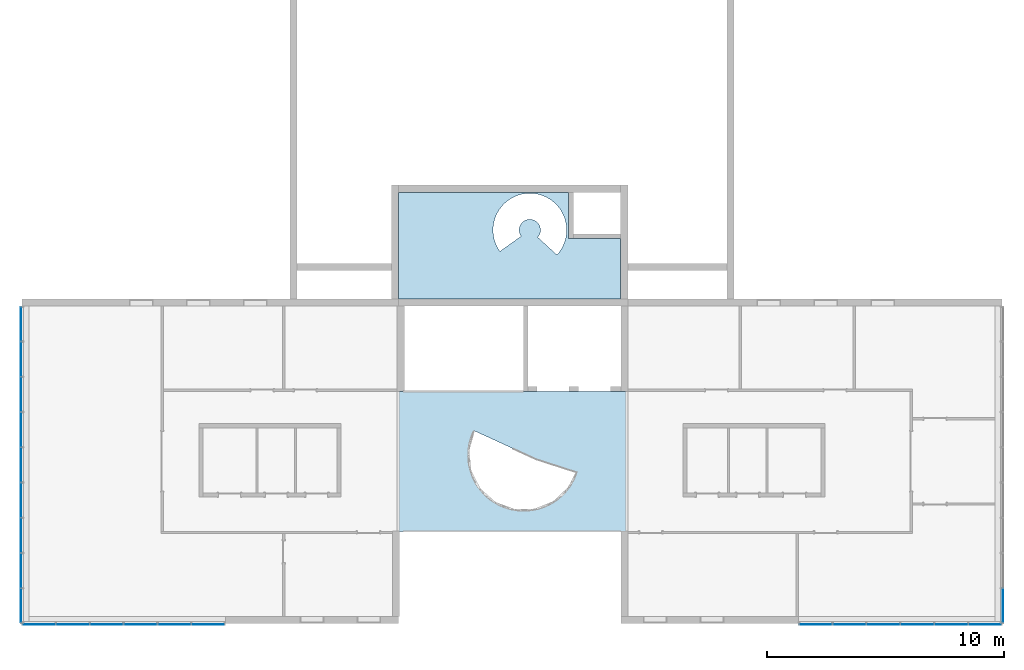
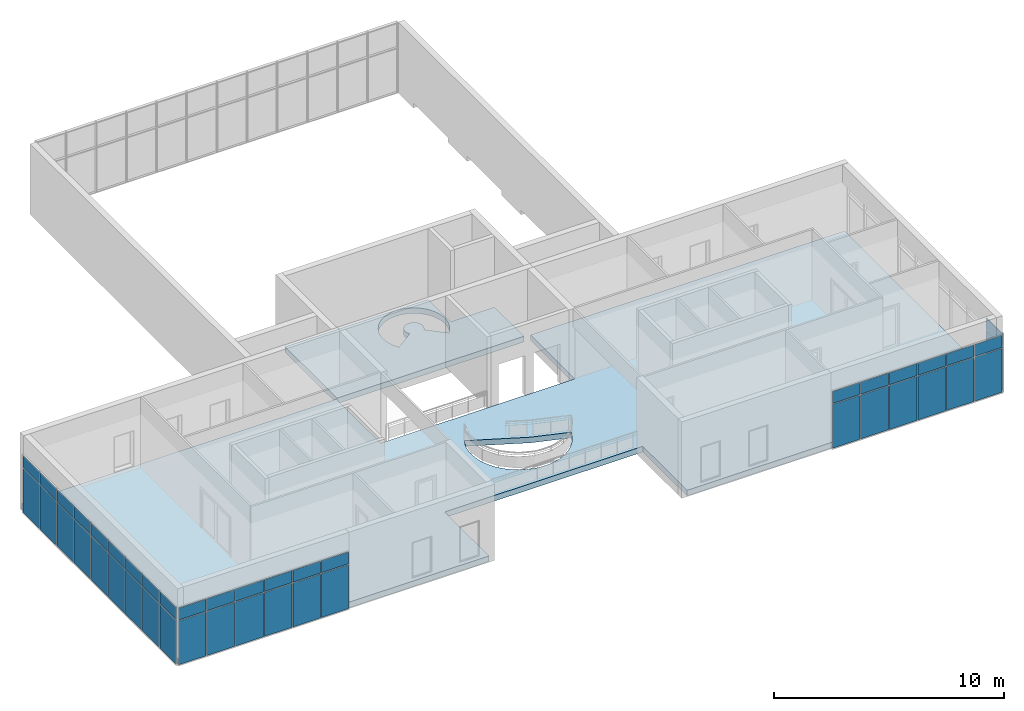
# One storey, part 8 of 13: 44 plates, 2 slabs, 2 openings, 4 elements without a shape of their own.
"""IFC2X3 building model written with IfcOpenShell, lengths in millimetres."""

import ifcopenshell
import ifcopenshell.guid

model = None  # the IFC model being written
_history = None  # IfcOwnerHistory: only IFC2X3 demands one
_inside = {}  # id of a spatial element -> (the spatial element, [elements in it])
_under = {}  # id of a project, library or spatial element -> (it, [spatial elements below it])
_declared = {}  # id of a project -> (the project, [libraries it declares])
_typed = {}  # id of a type object -> (the type object, [elements of that type])
_made_of = {}  # id of a material, layer set ... -> (it, [elements and type objects made of it])


def new_model(schema):
    """Start an empty IFC model of exactly this schema.

    Asked for "IFC4X3", IfcOpenShell would pick the latest addendum, in which some entities
    have other attributes; the version numbers below select the first issue.
    IFC2X3 requires an IfcOwnerHistory on every rooted entity: one is made here for all.
    """
    global model, _history
    if schema == "IFC4X3":
        model = ifcopenshell.file(schema_version=(4, 3, 0, 0))
    else:
        model = ifcopenshell.file(schema=schema)
    _inside.clear()
    _under.clear()
    _declared.clear()
    _typed.clear()
    _made_of.clear()
    _history = None
    if model.schema == "IFC2X3":
        org = make("IfcOrganization", Name="unknown")
        user = make(
            "IfcPersonAndOrganization",
            ThePerson=make("IfcPerson", FamilyName="unknown"),
            TheOrganization=org,
        )
        app = make(
            "IfcApplication",
            ApplicationDeveloper=org,
            Version="unknown",
            ApplicationFullName="unknown",
            ApplicationIdentifier="unknown",
        )
        _history = make(
            "IfcOwnerHistory",
            OwningUser=user,
            OwningApplication=app,
            ChangeAction="ADDED",
            CreationDate=0,
        )
    return model


def make(cls, **values):
    """One entity of the class cls with the attributes given. An attribute that is None is left unset."""
    return model.create_entity(
        cls, **{name: value for name, value in values.items() if value is not None}
    )


def entity(cls, *values):
    """Any entity or typed value of the class cls, its attributes in the order of the schema. None: left unset."""
    e = model.create_entity(cls)
    for i, value in enumerate(values):
        if value is not None:
            e[i] = value
    return e


def rooted(cls, **values):
    """An entity with a GlobalId (a new one), such as an element, a storey or a relation."""
    return make(cls, GlobalId=ifcopenshell.guid.new(), OwnerHistory=_history, **values)


def si_unit(unit_type, name, prefix=None):
    """IfcSIUnit, for example si_unit("LENGTHUNIT", "METRE", prefix="MILLI")."""
    return make("IfcSIUnit", UnitType=unit_type, Prefix=prefix, Name=name)


def converted_unit(unit_type, name, factor, base, dimensions=None, offset=None):
    """IfcConversionBasedUnit, such as the inch: factor (a typed value) times the base unit."""
    return make(
        "IfcConversionBasedUnit"
        if offset is None
        else "IfcConversionBasedUnitWithOffset",
        ConversionOffset=offset,
        Dimensions=None
        if dimensions is None
        else entity("IfcDimensionalExponents", *dimensions),
        UnitType=unit_type,
        Name=name,
        ConversionFactor=make(
            "IfcMeasureWithUnit", ValueComponent=factor, UnitComponent=base
        ),
    )


def derived_unit(unit_type, elements):
    """IfcDerivedUnit: a product of units, each with its exponent."""
    return make(
        "IfcDerivedUnit",
        Elements=[
            make("IfcDerivedUnitElement", Unit=unit, Exponent=power)
            for unit, power in elements
        ],
        UnitType=unit_type,
    )


def assignment(units):
    """IfcUnitAssignment: the units of a project."""
    return None if units is None else make("IfcUnitAssignment", Units=units)


def point(xyz):
    """IfcCartesianPoint."""
    return None if xyz is None else make("IfcCartesianPoint", Coordinates=xyz)


def direction(xyz):
    """IfcDirection."""
    return None if xyz is None else make("IfcDirection", DirectionRatios=xyz)


def frame(location, z_axis=None, x_axis=None):
    """IfcAxis2Placement3D, a coordinate frame: its origin and axes. An axis left out is left unset."""
    return make(
        "IfcAxis2Placement3D",
        Location=point(location),
        Axis=direction(z_axis),
        RefDirection=direction(x_axis),
    )


def frame_2d(location, x_axis=None):
    """IfcAxis2Placement2D, a coordinate frame in the plane: its origin and x axis."""
    return make(
        "IfcAxis2Placement2D", Location=point(location), RefDirection=direction(x_axis)
    )


def origin():
    """The frame at (0, 0, 0) with its axes left unset."""
    return frame((0.0, 0.0, 0.0))


def origin_2d_with_axis():
    """The frame at (0, 0) in the plane with the x axis (1, 0) written out."""
    return frame_2d((0.0, 0.0), x_axis=(1.0, 0.0))


def place(relative_to, where):
    """IfcLocalPlacement: puts the frame where relative to a parent placement (None: the world)."""
    return make(
        "IfcLocalPlacement", PlacementRelTo=relative_to, RelativePlacement=where
    )


def context(
    kind, dimensions, precision=None, world=None, true_north=None, identifier=None
):
    """IfcGeometricRepresentationContext, for example the 3D "Model" context."""
    return make(
        "IfcGeometricRepresentationContext",
        ContextIdentifier=identifier,
        ContextType=kind,
        CoordinateSpaceDimension=dimensions,
        Precision=precision,
        WorldCoordinateSystem=world,
        TrueNorth=true_north,
    )


def subcontext(parent, identifier, kind, view, scale=None):
    """IfcGeometricRepresentationSubContext, for example "Body" below "Model"."""
    return make(
        "IfcGeometricRepresentationSubContext",
        ContextIdentifier=identifier,
        ContextType=kind,
        ParentContext=parent,
        TargetScale=scale,
        TargetView=view,
    )


def project(units=None, contexts=None):
    """IfcProject with its units and contexts."""
    return rooted(
        "IfcProject",
        Name="project",
        RepresentationContexts=contexts,
        UnitsInContext=assignment(units),
    )


def spatial(cls, under=None, at=None, **own):
    """A site, building, storey or space (cls), placed at a placement, below another one or the project."""
    s = rooted(cls, ObjectPlacement=at, **own)
    if under is not None:
        _under.setdefault(under.id(), (under, []))[1].append(s)
    return s


def polyline(points):
    """IfcPolyline through the points."""
    return make("IfcPolyline", Points=[point(p) for p in points])


def circle_curve(where, radius):
    """IfcCircle in the frame where."""
    return make("IfcCircle", Position=where, Radius=radius)


def parameter(value):
    """IfcParameterValue: where a trimmed curve begins or ends, as a parameter of its basis curve."""
    return model.create_entity("IfcParameterValue", value)


def trimmed(basis, trim1, trim2, sense, master):
    """IfcTrimmedCurve: the piece of a basis curve between two trims."""
    return make(
        "IfcTrimmedCurve",
        BasisCurve=basis,
        Trim1=trim1,
        Trim2=trim2,
        SenseAgreement=sense,
        MasterRepresentation=master,
    )


def segment(curve, same_sense, transition):
    """IfcCompositeCurveSegment."""
    return make(
        "IfcCompositeCurveSegment",
        Transition=transition,
        SameSense=same_sense,
        ParentCurve=curve,
    )


def composite_curve(segments, self_intersect=None):
    """IfcCompositeCurve: segments joined end to end."""
    return make("IfcCompositeCurve", Segments=segments, SelfIntersect=self_intersect)


def profile(cls, at=None, kind="AREA", **sizes):
    """A parametric profile (cls). Its sizes go by their IFC names, for example OverallWidth=200.0."""
    return make(cls, ProfileType=kind, Position=at, **sizes)


def rectangle(**sizes):
    """IfcRectangleProfileDef."""
    return profile("IfcRectangleProfileDef", **sizes)


def outline(outer, holes=None, kind="AREA"):
    """IfcArbitraryClosedProfileDef: a profile drawn as a closed curve; with holes, ...WithVoids."""
    if holes is None:
        return make("IfcArbitraryClosedProfileDef", ProfileType=kind, OuterCurve=outer)
    return make(
        "IfcArbitraryProfileDefWithVoids",
        ProfileType=kind,
        OuterCurve=outer,
        InnerCurves=holes,
    )


def extrude(swept, where, along, depth):
    """IfcExtrudedAreaSolid: the profile swept, set in the frame where, extruded along a direction by depth."""
    return make(
        "IfcExtrudedAreaSolid",
        SweptArea=swept,
        Position=where,
        ExtrudedDirection=direction(along),
        Depth=depth,
    )


def shape(context_of_items, identifier, shape_type, items):
    """IfcShapeRepresentation: the items that make up one representation, for example the "Body"."""
    return make(
        "IfcShapeRepresentation",
        ContextOfItems=context_of_items,
        RepresentationIdentifier=identifier,
        RepresentationType=shape_type,
        Items=items,
    )


def source(mapping_origin, context_of_items, identifier, shape_type, items):
    """IfcRepresentationMap: a shape defined once, which mapped items show again and again."""
    return make(
        "IfcRepresentationMap",
        MappingOrigin=mapping_origin,
        MappedRepresentation=shape(context_of_items, identifier, shape_type, items),
    )


def transform(
    local_origin,
    x_axis=None,
    y_axis=None,
    z_axis=None,
    scale=None,
    scale2=None,
    scale3=None,
    uniform=True,
):
    """IfcCartesianTransformationOperator3D, or its non-uniform kind. x_axis, y_axis, z_axis: its Axis1, 2, 3."""
    if uniform:
        return make(
            "IfcCartesianTransformationOperator3D",
            Axis1=direction(x_axis),
            Axis2=direction(y_axis),
            LocalOrigin=point(local_origin),
            Scale=scale,
            Axis3=direction(z_axis),
        )
    return make(
        "IfcCartesianTransformationOperator3DnonUniform",
        Axis1=direction(x_axis),
        Axis2=direction(y_axis),
        LocalOrigin=point(local_origin),
        Scale=scale,
        Axis3=direction(z_axis),
        Scale2=scale2,
        Scale3=scale3,
    )


def mapped(mapping_source, mapping_target):
    """IfcMappedItem: shows the shape of a source again, moved by a transform."""
    return make(
        "IfcMappedItem", MappingSource=mapping_source, MappingTarget=mapping_target
    )


def material(Name=None, Category=None):
    """IfcMaterial."""
    return make("IfcMaterial", Name=Name, Category=Category)


def layer(
    of_material, thickness, ventilated=None, Name=None, Category=None, Priority=None
):
    """IfcMaterialLayer: one layer of a wall or slab, of a material (None: an air gap)."""
    return make(
        "IfcMaterialLayer",
        Material=of_material,
        LayerThickness=thickness,
        IsVentilated=ventilated,
        Name=Name,
        Category=Category,
        Priority=Priority,
    )


def layer_set(layers, Name=None):
    """IfcMaterialLayerSet."""
    return make("IfcMaterialLayerSet", MaterialLayers=layers, LayerSetName=Name)


def layer_usage(for_layer_set, set_direction, sense, offset, extent=None):
    """IfcMaterialLayerSetUsage: how a layer set lies in its element."""
    return make(
        "IfcMaterialLayerSetUsage",
        ForLayerSet=for_layer_set,
        LayerSetDirection=set_direction,
        DirectionSense=sense,
        OffsetFromReferenceLine=offset,
        ReferenceExtent=extent,
    )


def made_of(thing, what):
    """Note that an element or type object is made of a material, layer set ...; save() writes the relation."""
    if what is not None:
        _made_of.setdefault(what.id(), (what, []))[1].append(thing)
    return thing


def type_object(cls, material=None, **own):
    """A type object (cls), such as IfcWallType, which elements share."""
    return made_of(rooted(cls, **own), material)


def type_shapes(of_type, sources):
    """Give a type object the sources (RepresentationMaps) that its elements show as mapped items."""
    of_type.RepresentationMaps = sources


def element(
    cls,
    number,
    at=None,
    inside=None,
    cuts=None,
    type_object=None,
    material=None,
    context=None,
    identifier="Body",
    shape_type=None,
    held_by="IfcProductDefinitionShape",
    body=None,
    shapes=None,
    **own,
):
    """One element of the class cls, such as IfcWall. Its Tag is "e" and its number.

    at: its placement. inside: the storey or other place that contains it. cuts: it is an
    opening in that element (IfcRelVoidsElement). A single representation is given by context,
    identifier, shape_type and body (its items); several are given by shapes. held_by: the class
    of the entity that holds the representations. save() writes the other relations.
    """
    e = rooted(cls, Tag="e%d" % number, ObjectPlacement=at, **own)
    if body is not None:
        shapes = [shape(context, identifier, shape_type, body)]
    if shapes is not None:
        e.Representation = make(held_by, Representations=shapes)
    if inside is not None:
        _inside.setdefault(inside.id(), (inside, []))[1].append(e)
    if cuts is not None:
        rooted(
            "IfcRelVoidsElement", RelatingBuildingElement=cuts, RelatedOpeningElement=e
        )
    if type_object is not None:
        _typed.setdefault(type_object.id(), (type_object, []))[1].append(e)
    return made_of(e, material)


def aggregate(whole, parts):
    """IfcRelAggregates: a whole, such as a stair, and the parts it consists of."""
    return rooted("IfcRelAggregates", RelatingObject=whole, RelatedObjects=parts)


def save(model, path):
    """Write the relations noted so far, then the file.

    IfcRelAggregates (storeys below a building ...), IfcRelContainedInSpatialStructure (elements
    in a storey), IfcRelDefinesByType, IfcRelAssociatesMaterial and IfcRelDeclares: one each for
    every whole, place, type object, material and project.
    """
    for whole, parts in _under.values():
        aggregate(whole, parts)
    for where, things in _inside.values():
        rooted(
            "IfcRelContainedInSpatialStructure",
            RelatedElements=things,
            RelatingStructure=where,
        )
    for kind, things in _typed.values():
        rooted("IfcRelDefinesByType", RelatedObjects=things, RelatingType=kind)
    for what, things in _made_of.values():
        rooted("IfcRelAssociatesMaterial", RelatedObjects=things, RelatingMaterial=what)
    for by, libraries in _declared.values():
        rooted("IfcRelDeclares", RelatingContext=by, RelatedDefinitions=libraries)
    model.write(path)


model = new_model("IFC2X3")

# Units and contexts
model_context = context("Model", 3, precision=0.01, world=origin(), true_north=direction((6.12303176911189e-17, 1.0)))
context_of_model = context(None, 3, precision=0.01, world=origin(), true_north=direction((6.12303176911189e-17, 1.0)))
body_context = subcontext(model_context, "Body", "Model", "MODEL_VIEW")
ifc_project = project(units=[si_unit("LENGTHUNIT", "METRE", prefix="MILLI"), si_unit("AREAUNIT", "SQUARE_METRE"), si_unit("VOLUMEUNIT", "CUBIC_METRE"), converted_unit("PLANEANGLEUNIT", "DEGREE", entity("IfcRatioMeasure", 0.0174532925199433), si_unit("PLANEANGLEUNIT", "RADIAN"), dimensions=[0, 0, 0, 0, 0, 0, 0]), si_unit("MASSUNIT", "GRAM", prefix="KILO"), si_unit("TIMEUNIT", "SECOND"), si_unit("FREQUENCYUNIT", "HERTZ"), si_unit("THERMODYNAMICTEMPERATUREUNIT", "DEGREE_CELSIUS"), derived_unit("THERMALTRANSMITTANCEUNIT", [(si_unit("MASSUNIT", "GRAM", prefix="KILO"), 1), (si_unit("THERMODYNAMICTEMPERATUREUNIT", "KELVIN"), -1), (si_unit("TIMEUNIT", "SECOND"), -3)]), derived_unit("VOLUMETRICFLOWRATEUNIT", [(si_unit("LENGTHUNIT", "METRE"), 3), (si_unit("TIMEUNIT", "SECOND"), -1)]), si_unit("ELECTRICCURRENTUNIT", "AMPERE"), si_unit("ELECTRICVOLTAGEUNIT", "VOLT"), si_unit("POWERUNIT", "WATT"), si_unit("FORCEUNIT", "NEWTON", prefix="KILO"), si_unit("ILLUMINANCEUNIT", "LUX"), si_unit("LUMINOUSFLUXUNIT", "LUMEN"), si_unit("LUMINOUSINTENSITYUNIT", "CANDELA"), si_unit("PRESSUREUNIT", "PASCAL")], contexts=[model_context, context_of_model])

# Site, building, storey
site_placement = place(None, origin())
site = spatial("IfcSite", under=ifc_project, at=site_placement, CompositionType="ELEMENT")
building_placement = place(site_placement, origin())
building = spatial("IfcBuilding", under=site, at=building_placement, CompositionType="ELEMENT")
storey_placement = place(building_placement, frame((0.0, 0.0, 3750.0)))
storey = spatial("IfcBuildingStorey", under=building, at=storey_placement, Name="02. 2 etg.", CompositionType="ELEMENT", Elevation=3750.00000000068)

# Curtain wall, plates
curtain_wall_type = type_object("IfcCurtainWallType", Name="Curtain Wall:Storefront", PredefinedType="NOTDEFINED")
curtain_wall_1_placement = place(storey_placement, frame((0.0, 0.0, -3750.0)))
curtain_wall_1 = element("IfcCurtainWall", 1, at=curtain_wall_1_placement, inside=storey, type_object=curtain_wall_type, Name="Curtain Wall:Storefront", ObjectType="Curtain Wall:Storefront")
ifc_material_1 = material(Name="Glass")
plate_type_1 = type_object("IfcPlateType", Name="Glazed", PredefinedType="CURTAIN_PANEL", material=ifc_material_1)
shared_shape_1 = source(origin(), body_context, "Body", "SweptSolid", [
    extrude(rectangle(XDim=25.0, YDim=1411.66666666667, at=frame_2d((0.0, 1.13686837721616e-13), x_axis=(1.0, 0.0))), frame((705.833333333337, 12.5, 0.0), z_axis=(0.0, 0.0, 1.0), x_axis=(0.0, 1.0, 0.0)), (0.0, 0.0, 1.0), 2325.0),
])
type_shapes(plate_type_1, [shared_shape_1])
plate_1_placement = place(curtain_wall_1_placement, frame((-289.5, -110.0, 3500.0), z_axis=(0.0, 0.0, 1.0), x_axis=(0.0, -1.0, 0.0)))
plate_1 = element("IfcPlate", 2, at=plate_1_placement, type_object=plate_type_1, material=ifc_material_1, Name="System Panel:Glazed", ObjectType="Glazed", context=body_context, shape_type="MappedRepresentation", body=[
    mapped(shared_shape_1, transform((0.0, 0.0, 0.0), scale=1.0)),
])
plate_2_placement = place(curtain_wall_1_placement, frame((-289.500000000019, -11978.3333333333, 3500.0), z_axis=(0.0, 0.0, 1.0), x_axis=(0.0, -1.0, 0.0)))
plate_2 = element("IfcPlate", 3, at=plate_2_placement, type_object=plate_type_1, material=ifc_material_1, Name="System Panel:Glazed", ObjectType="Glazed", context=body_context, shape_type="MappedRepresentation", body=[
    mapped(shared_shape_1, transform((0.0, 0.0, 0.0), scale=1.0)),
])
plate_type_2 = type_object("IfcPlateType", Name="Glazed", PredefinedType="CURTAIN_PANEL", material=ifc_material_1)
shared_shape_2 = source(origin(), body_context, "Body", "SweptSolid", [
    extrude(rectangle(XDim=25.0, YDim=1436.66666666667, at=origin_2d_with_axis()), frame((718.333333333336, 12.5, 0.0), z_axis=(0.0, 0.0, 1.0), x_axis=(0.0, 1.0, 0.0)), (0.0, 0.0, 1.0), 2325.0),
])
type_shapes(plate_type_2, [shared_shape_2])
plate_3_placement = place(curtain_wall_1_placement, frame((-289.500000000003, -1571.66666666661, 3500.0), z_axis=(0.0, 0.0, 1.0), x_axis=(0.0, -1.0, 0.0)))
plate_3 = element("IfcPlate", 4, at=plate_3_placement, type_object=plate_type_2, material=ifc_material_1, Name="System Panel:Glazed", ObjectType="Glazed", context=body_context, shape_type="MappedRepresentation", body=[
    mapped(shared_shape_2, transform((0.0, 0.0, 0.0), scale=1.0)),
])
plate_4_placement = place(curtain_wall_1_placement, frame((-289.500000000005, -3058.33333333329, 3500.0), z_axis=(0.0, 0.0, 1.0), x_axis=(0.0, -1.0, 0.0)))
plate_4 = element("IfcPlate", 5, at=plate_4_placement, type_object=plate_type_2, material=ifc_material_1, Name="System Panel:Glazed", ObjectType="Glazed", context=body_context, shape_type="MappedRepresentation", body=[
    mapped(shared_shape_2, transform((0.0, 0.0, 0.0), scale=1.0)),
])
plate_5_placement = place(curtain_wall_1_placement, frame((-289.500000000007, -4545.0, 3500.0), z_axis=(0.0, 0.0, 1.0), x_axis=(0.0, -1.0, 0.0)))
plate_5 = element("IfcPlate", 6, at=plate_5_placement, type_object=plate_type_2, material=ifc_material_1, Name="System Panel:Glazed", ObjectType="Glazed", context=body_context, shape_type="MappedRepresentation", body=[
    mapped(shared_shape_2, transform((0.0, 0.0, 0.0), scale=1.0)),
])
plate_6_placement = place(curtain_wall_1_placement, frame((-289.50000000001, -6031.66666666663, 3500.0), z_axis=(0.0, 0.0, 1.0), x_axis=(0.0, -1.0, 0.0)))
plate_6 = element("IfcPlate", 7, at=plate_6_placement, type_object=plate_type_2, material=ifc_material_1, Name="System Panel:Glazed", ObjectType="Glazed", context=body_context, shape_type="MappedRepresentation", body=[
    mapped(shared_shape_2, transform((0.0, 0.0, 0.0), scale=1.0)),
])
plate_7_placement = place(curtain_wall_1_placement, frame((-289.500000000012, -7518.33333333331, 3500.0), z_axis=(0.0, 0.0, 1.0), x_axis=(0.0, -1.0, 0.0)))
plate_7 = element("IfcPlate", 8, at=plate_7_placement, type_object=plate_type_2, material=ifc_material_1, Name="System Panel:Glazed", ObjectType="Glazed", context=body_context, shape_type="MappedRepresentation", body=[
    mapped(shared_shape_2, transform((0.0, 0.0, 0.0), scale=1.0)),
])
plate_8_placement = place(curtain_wall_1_placement, frame((-289.500000000015, -9005.0, 3500.0), z_axis=(0.0, 0.0, 1.0), x_axis=(0.0, -1.0, 0.0)))
plate_8 = element("IfcPlate", 9, at=plate_8_placement, type_object=plate_type_2, material=ifc_material_1, Name="System Panel:Glazed", ObjectType="Glazed", context=body_context, shape_type="MappedRepresentation", body=[
    mapped(shared_shape_2, transform((0.0, 0.0, 0.0), scale=1.0)),
])
plate_9_placement = place(curtain_wall_1_placement, frame((-289.500000000017, -10491.6666666667, 3500.0), z_axis=(0.0, 0.0, 1.0), x_axis=(0.0, -1.0, 0.0)))
plate_9 = element("IfcPlate", 10, at=plate_9_placement, type_object=plate_type_2, material=ifc_material_1, Name="System Panel:Glazed", ObjectType="Glazed", context=body_context, shape_type="MappedRepresentation", body=[
    mapped(shared_shape_2, transform((0.0, 0.0, 0.0), scale=1.0)),
])
plate_type_3 = type_object("IfcPlateType", Name="Glazed", PredefinedType="CURTAIN_PANEL", material=ifc_material_1)
shared_shape_3 = source(origin(), body_context, "Body", "SweptSolid", [
    extrude(rectangle(XDim=25.0, YDim=1411.66666666667, at=frame_2d((0.0, 5.6843418860808e-14), x_axis=(1.0, 0.0))), frame((705.833333333337, 12.5, 0.0), z_axis=(0.0, 0.0, 1.0), x_axis=(0.0, 1.0, 0.0)), (0.0, 0.0, 1.0), 625.000000000002),
])
type_shapes(plate_type_3, [shared_shape_3])
plate_10_placement = place(curtain_wall_1_placement, frame((-289.5, -110.0, 5875.0), z_axis=(0.0, 0.0, 1.0), x_axis=(0.0, -1.0, 0.0)))
plate_10 = element("IfcPlate", 11, at=plate_10_placement, type_object=plate_type_3, material=ifc_material_1, Name="System Panel:Glazed", ObjectType="Glazed", context=body_context, shape_type="MappedRepresentation", body=[
    mapped(shared_shape_3, transform((0.0, 0.0, 0.0), scale=1.0)),
])
plate_11_placement = place(curtain_wall_1_placement, frame((-289.500000000019, -11978.3333333333, 5875.0), z_axis=(0.0, 0.0, 1.0), x_axis=(0.0, -1.0, 0.0)))
plate_11 = element("IfcPlate", 12, at=plate_11_placement, type_object=plate_type_3, material=ifc_material_1, Name="System Panel:Glazed", ObjectType="Glazed", context=body_context, shape_type="MappedRepresentation", body=[
    mapped(shared_shape_3, transform((0.0, 0.0, 0.0), scale=1.0)),
])
plate_type_4 = type_object("IfcPlateType", Name="Glazed", PredefinedType="CURTAIN_PANEL", material=ifc_material_1)
shared_shape_4 = source(origin(), body_context, "Body", "SweptSolid", [
    extrude(rectangle(XDim=25.0, YDim=1436.66666666667, at=origin_2d_with_axis()), frame((718.333333333337, 12.5, 0.0), z_axis=(0.0, 0.0, 1.0), x_axis=(0.0, 1.0, 0.0)), (0.0, 0.0, 1.0), 625.000000000002),
])
type_shapes(plate_type_4, [shared_shape_4])
plate_12_placement = place(curtain_wall_1_placement, frame((-289.500000000003, -1571.66666666661, 5875.0), z_axis=(0.0, 0.0, 1.0), x_axis=(0.0, -1.0, 0.0)))
plate_12 = element("IfcPlate", 13, at=plate_12_placement, type_object=plate_type_4, material=ifc_material_1, Name="System Panel:Glazed", ObjectType="Glazed", context=body_context, shape_type="MappedRepresentation", body=[
    mapped(shared_shape_4, transform((0.0, 0.0, 0.0), scale=1.0)),
])
plate_13_placement = place(curtain_wall_1_placement, frame((-289.500000000005, -3058.33333333329, 5875.0), z_axis=(0.0, 0.0, 1.0), x_axis=(0.0, -1.0, 0.0)))
plate_13 = element("IfcPlate", 14, at=plate_13_placement, type_object=plate_type_4, material=ifc_material_1, Name="System Panel:Glazed", ObjectType="Glazed", context=body_context, shape_type="MappedRepresentation", body=[
    mapped(shared_shape_4, transform((0.0, 0.0, 0.0), scale=1.0)),
])
plate_14_placement = place(curtain_wall_1_placement, frame((-289.500000000007, -4545.0, 5875.0), z_axis=(0.0, 0.0, 1.0), x_axis=(0.0, -1.0, 0.0)))
plate_14 = element("IfcPlate", 15, at=plate_14_placement, type_object=plate_type_4, material=ifc_material_1, Name="System Panel:Glazed", ObjectType="Glazed", context=body_context, shape_type="MappedRepresentation", body=[
    mapped(shared_shape_4, transform((0.0, 0.0, 0.0), scale=1.0)),
])
plate_15_placement = place(curtain_wall_1_placement, frame((-289.50000000001, -6031.66666666663, 5875.0), z_axis=(0.0, 0.0, 1.0), x_axis=(0.0, -1.0, 0.0)))
plate_15 = element("IfcPlate", 16, at=plate_15_placement, type_object=plate_type_4, material=ifc_material_1, Name="System Panel:Glazed", ObjectType="Glazed", context=body_context, shape_type="MappedRepresentation", body=[
    mapped(shared_shape_4, transform((0.0, 0.0, 0.0), scale=1.0)),
])
plate_16_placement = place(curtain_wall_1_placement, frame((-289.500000000012, -7518.33333333331, 5875.0), z_axis=(0.0, 0.0, 1.0), x_axis=(0.0, -1.0, 0.0)))
plate_16 = element("IfcPlate", 17, at=plate_16_placement, type_object=plate_type_4, material=ifc_material_1, Name="System Panel:Glazed", ObjectType="Glazed", context=body_context, shape_type="MappedRepresentation", body=[
    mapped(shared_shape_4, transform((0.0, 0.0, 0.0), scale=1.0)),
])
plate_17_placement = place(curtain_wall_1_placement, frame((-289.500000000015, -9005.0, 5875.0), z_axis=(0.0, 0.0, 1.0), x_axis=(0.0, -1.0, 0.0)))
plate_17 = element("IfcPlate", 18, at=plate_17_placement, type_object=plate_type_4, material=ifc_material_1, Name="System Panel:Glazed", ObjectType="Glazed", context=body_context, shape_type="MappedRepresentation", body=[
    mapped(shared_shape_4, transform((0.0, 0.0, 0.0), scale=1.0)),
])
plate_18_placement = place(curtain_wall_1_placement, frame((-289.500000000017, -10491.6666666667, 5875.0), z_axis=(0.0, 0.0, 1.0), x_axis=(0.0, -1.0, 0.0)))
plate_18 = element("IfcPlate", 19, at=plate_18_placement, type_object=plate_type_4, material=ifc_material_1, Name="System Panel:Glazed", ObjectType="Glazed", context=body_context, shape_type="MappedRepresentation", body=[
    mapped(shared_shape_4, transform((0.0, 0.0, 0.0), scale=1.0)),
])
aggregate(curtain_wall_1, [plate_1, plate_3, plate_4, plate_5, plate_6, plate_7, plate_8, plate_9, plate_2, plate_10, plate_12, plate_13, plate_14, plate_15, plate_16, plate_17, plate_18, plate_11])

curtain_wall_2_placement = place(storey_placement, frame((0.0, 0.0, -3750.0)))
curtain_wall_2 = element("IfcCurtainWall", 20, at=curtain_wall_2_placement, inside=storey, type_object=curtain_wall_type, Name="Curtain Wall:Storefront", ObjectType="Curtain Wall:Storefront")
plate_type_5 = type_object("IfcPlateType", Name="Glazed", PredefinedType="CURTAIN_PANEL", material=ifc_material_1)
shared_shape_5 = source(origin(), body_context, "Body", "SweptSolid", [
    extrude(rectangle(XDim=25.0, YDim=1355.0, at=frame_2d((2.66453525910038e-15, 0.0), x_axis=(1.0, 0.0))), frame((677.500000000002, 12.5, 0.0), z_axis=(0.0, 0.0, 1.0), x_axis=(0.0, 1.0, 0.0)), (0.0, 0.0, 1.0), 2325.0),
])
type_shapes(plate_type_5, [shared_shape_5])
plate_19_placement = place(curtain_wall_2_placement, frame((-190.0, -13489.5, 3500.0)))
plate_19 = element("IfcPlate", 21, at=plate_19_placement, type_object=plate_type_5, material=ifc_material_1, Name="System Panel:Glazed", ObjectType="Glazed", context=body_context, shape_type="MappedRepresentation", body=[
    mapped(shared_shape_5, transform((0.0, 0.0, 0.0), scale=1.0)),
])
plate_20_placement = place(curtain_wall_2_placement, frame((6935.0, -13489.5, 3500.0)))
plate_20 = element("IfcPlate", 22, at=plate_20_placement, type_object=plate_type_5, material=ifc_material_1, Name="System Panel:Glazed", ObjectType="Glazed", context=body_context, shape_type="MappedRepresentation", body=[
    mapped(shared_shape_5, transform((0.0, 0.0, 0.0), scale=1.0)),
])
plate_type_6 = type_object("IfcPlateType", Name="Glazed", PredefinedType="CURTAIN_PANEL", material=ifc_material_1)
shared_shape_6 = source(origin(), body_context, "Body", "SweptSolid", [
    extrude(rectangle(XDim=25.0, YDim=1380.0, at=frame_2d((2.66453525910038e-15, 0.0), x_axis=(1.0, 0.0))), frame((690.0, 12.5, 0.0), z_axis=(0.0, 0.0, 1.0), x_axis=(0.0, 1.0, 0.0)), (0.0, 0.0, 1.0), 2325.0),
])
type_shapes(plate_type_6, [shared_shape_6])
plate_21_placement = place(curtain_wall_2_placement, frame((1215.0, -13489.5, 3500.0)))
plate_21 = element("IfcPlate", 23, at=plate_21_placement, type_object=plate_type_6, material=ifc_material_1, Name="System Panel:Glazed", ObjectType="Glazed", context=body_context, shape_type="MappedRepresentation", body=[
    mapped(shared_shape_6, transform((0.0, 0.0, 0.0), scale=1.0)),
])
plate_22_placement = place(curtain_wall_2_placement, frame((2645.0, -13489.5, 3500.0)))
plate_22 = element("IfcPlate", 24, at=plate_22_placement, type_object=plate_type_6, material=ifc_material_1, Name="System Panel:Glazed", ObjectType="Glazed", context=body_context, shape_type="MappedRepresentation", body=[
    mapped(shared_shape_6, transform((0.0, 0.0, 0.0), scale=1.0)),
])
plate_23_placement = place(curtain_wall_2_placement, frame((4075.0, -13489.5, 3500.0)))
plate_23 = element("IfcPlate", 25, at=plate_23_placement, type_object=plate_type_6, material=ifc_material_1, Name="System Panel:Glazed", ObjectType="Glazed", context=body_context, shape_type="MappedRepresentation", body=[
    mapped(shared_shape_6, transform((0.0, 0.0, 0.0), scale=1.0)),
])
plate_24_placement = place(curtain_wall_2_placement, frame((5505.0, -13489.5, 3500.0)))
plate_24 = element("IfcPlate", 26, at=plate_24_placement, type_object=plate_type_6, material=ifc_material_1, Name="System Panel:Glazed", ObjectType="Glazed", context=body_context, shape_type="MappedRepresentation", body=[
    mapped(shared_shape_6, transform((0.0, 0.0, 0.0), scale=1.0)),
])
plate_type_7 = type_object("IfcPlateType", Name="Glazed", PredefinedType="CURTAIN_PANEL", material=ifc_material_1)
shared_shape_7 = source(origin(), body_context, "Body", "SweptSolid", [
    extrude(rectangle(XDim=25.0, YDim=1355.0, at=frame_2d((1.77635683940025e-15, 5.6843418860808e-14), x_axis=(1.0, 0.0))), frame((677.500000000002, 12.5, 0.0), z_axis=(0.0, 0.0, 1.0), x_axis=(0.0, 1.0, 0.0)), (0.0, 0.0, 1.0), 625.000000000002),
])
type_shapes(plate_type_7, [shared_shape_7])
plate_25_placement = place(curtain_wall_2_placement, frame((-190.0, -13489.5, 5875.0)))
plate_25 = element("IfcPlate", 27, at=plate_25_placement, type_object=plate_type_7, material=ifc_material_1, Name="System Panel:Glazed", ObjectType="Glazed", context=body_context, shape_type="MappedRepresentation", body=[
    mapped(shared_shape_7, transform((0.0, 0.0, 0.0), scale=1.0)),
])
plate_26_placement = place(curtain_wall_2_placement, frame((6935.0, -13489.5, 5875.0)))
plate_26 = element("IfcPlate", 28, at=plate_26_placement, type_object=plate_type_7, material=ifc_material_1, Name="System Panel:Glazed", ObjectType="Glazed", context=body_context, shape_type="MappedRepresentation", body=[
    mapped(shared_shape_7, transform((0.0, 0.0, 0.0), scale=1.0)),
])
plate_type_8 = type_object("IfcPlateType", Name="Glazed", PredefinedType="CURTAIN_PANEL", material=ifc_material_1)
shared_shape_8 = source(origin(), body_context, "Body", "SweptSolid", [
    extrude(rectangle(XDim=25.0, YDim=1380.0, at=frame_2d((2.66453525910038e-15, 0.0), x_axis=(1.0, 0.0))), frame((690.0, 12.5, 0.0), z_axis=(0.0, 0.0, 1.0), x_axis=(0.0, 1.0, 0.0)), (0.0, 0.0, 1.0), 625.000000000002),
])
type_shapes(plate_type_8, [shared_shape_8])
plate_27_placement = place(curtain_wall_2_placement, frame((1215.0, -13489.5, 5875.0)))
plate_27 = element("IfcPlate", 29, at=plate_27_placement, type_object=plate_type_8, material=ifc_material_1, Name="System Panel:Glazed", ObjectType="Glazed", context=body_context, shape_type="MappedRepresentation", body=[
    mapped(shared_shape_8, transform((0.0, 0.0, 0.0), scale=1.0)),
])
plate_28_placement = place(curtain_wall_2_placement, frame((2645.0, -13489.5, 5875.0)))
plate_28 = element("IfcPlate", 30, at=plate_28_placement, type_object=plate_type_8, material=ifc_material_1, Name="System Panel:Glazed", ObjectType="Glazed", context=body_context, shape_type="MappedRepresentation", body=[
    mapped(shared_shape_8, transform((0.0, 0.0, 0.0), scale=1.0)),
])
plate_29_placement = place(curtain_wall_2_placement, frame((4075.0, -13489.5, 5875.0)))
plate_29 = element("IfcPlate", 31, at=plate_29_placement, type_object=plate_type_8, material=ifc_material_1, Name="System Panel:Glazed", ObjectType="Glazed", context=body_context, shape_type="MappedRepresentation", body=[
    mapped(shared_shape_8, transform((0.0, 0.0, 0.0), scale=1.0)),
])
plate_30_placement = place(curtain_wall_2_placement, frame((5505.0, -13489.5, 5875.0)))
plate_30 = element("IfcPlate", 32, at=plate_30_placement, type_object=plate_type_8, material=ifc_material_1, Name="System Panel:Glazed", ObjectType="Glazed", context=body_context, shape_type="MappedRepresentation", body=[
    mapped(shared_shape_8, transform((0.0, 0.0, 0.0), scale=1.0)),
])
aggregate(curtain_wall_2, [plate_19, plate_21, plate_22, plate_23, plate_24, plate_20, plate_25, plate_27, plate_28, plate_29, plate_30, plate_26])

curtain_wall_3_placement = place(storey_placement, frame((0.0, 0.0, -3750.0)))
curtain_wall_3 = element("IfcCurtainWall", 33, at=curtain_wall_3_placement, inside=storey, type_object=curtain_wall_type, Name="Curtain Wall:Storefront", ObjectType="Curtain Wall:Storefront")
plate_type_9 = type_object("IfcPlateType", Name="Glazed", PredefinedType="CURTAIN_PANEL", material=ifc_material_1)
shared_shape_9 = source(origin(), body_context, "Body", "SweptSolid", [
    extrude(rectangle(XDim=25.0, YDim=1411.66666666667, at=origin_2d_with_axis()), frame((705.833333333333, 12.5, 0.0), z_axis=(0.0, 0.0, 1.0), x_axis=(0.0, 1.0, 0.0)), (0.0, 0.0, 1.0), 2325.0),
])
type_shapes(plate_type_9, [shared_shape_9])
plate_31_placement = place(curtain_wall_3_placement, frame((41122.7357123495, -11978.3333333333, 3500.0), z_axis=(0.0, 0.0, 1.0), x_axis=(0.0, -1.0, 0.0)))
plate_31 = element("IfcPlate", 34, at=plate_31_placement, type_object=plate_type_9, material=ifc_material_1, Name="System Panel:Glazed", ObjectType="Glazed", context=body_context, shape_type="MappedRepresentation", body=[
    mapped(shared_shape_9, transform((0.0, 0.0, 0.0), scale=1.0)),
])
plate_type_10 = type_object("IfcPlateType", Name="Glazed", PredefinedType="CURTAIN_PANEL", material=ifc_material_1)
shared_shape_10 = source(origin(), body_context, "Body", "SweptSolid", [
    extrude(rectangle(XDim=25.0, YDim=1411.66666666667, at=origin_2d_with_axis()), frame((705.833333333333, 12.5, 0.0), z_axis=(0.0, 0.0, 1.0), x_axis=(0.0, 1.0, 0.0)), (0.0, 0.0, 1.0), 625.000000000002),
])
type_shapes(plate_type_10, [shared_shape_10])
plate_32_placement = place(curtain_wall_3_placement, frame((41122.7357123495, -11978.3333333333, 5875.0), z_axis=(0.0, 0.0, 1.0), x_axis=(0.0, -1.0, 0.0)))
plate_32 = element("IfcPlate", 35, at=plate_32_placement, type_object=plate_type_10, material=ifc_material_1, Name="System Panel:Glazed", ObjectType="Glazed", context=body_context, shape_type="MappedRepresentation", body=[
    mapped(shared_shape_10, transform((0.0, 0.0, 0.0), scale=1.0)),
])
aggregate(curtain_wall_3, [plate_31, plate_32])

curtain_wall_4_placement = place(storey_placement, frame((0.0, 0.0, -3750.0)))
curtain_wall_4 = element("IfcCurtainWall", 36, at=curtain_wall_4_placement, inside=storey, type_object=curtain_wall_type, Name="Curtain Wall:Storefront", ObjectType="Curtain Wall:Storefront")
plate_type_11 = type_object("IfcPlateType", Name="Glazed", PredefinedType="CURTAIN_PANEL", material=ifc_material_1)
shared_shape_11 = source(origin(), body_context, "Body", "SweptSolid", [
    extrude(rectangle(XDim=25.0, YDim=1356.66666666667, at=origin_2d_with_axis()), frame((678.333333333335, 12.5, 0.0), z_axis=(0.0, 0.0, 1.0), x_axis=(0.0, 1.0, 0.0)), (0.0, 0.0, 1.0), 2325.0),
])
type_shapes(plate_type_11, [shared_shape_11])
plate_33_placement = place(curtain_wall_4_placement, frame((41048.2357123495, -13464.5, 3500.0), z_axis=(0.0, 0.0, 1.0), x_axis=(-1.0, 0.0, 0.0)))
plate_33 = element("IfcPlate", 37, at=plate_33_placement, type_object=plate_type_11, material=ifc_material_1, Name="System Panel:Glazed", ObjectType="Glazed", context=body_context, shape_type="MappedRepresentation", body=[
    mapped(shared_shape_11, transform((0.0, 0.0, 0.0), scale=1.0)),
])
plate_34_placement = place(curtain_wall_4_placement, frame((33914.9023790161, -13464.5, 3500.0), z_axis=(0.0, 0.0, 1.0), x_axis=(-1.0, 0.0, 0.0)))
plate_34 = element("IfcPlate", 38, at=plate_34_placement, type_object=plate_type_11, material=ifc_material_1, Name="System Panel:Glazed", ObjectType="Glazed", context=body_context, shape_type="MappedRepresentation", body=[
    mapped(shared_shape_11, transform((0.0, 0.0, 0.0), scale=1.0)),
])
plate_type_12 = type_object("IfcPlateType", Name="Glazed", PredefinedType="CURTAIN_PANEL", material=ifc_material_1)
shared_shape_12 = source(origin(), body_context, "Body", "SweptSolid", [
    extrude(rectangle(XDim=25.0, YDim=1381.66666666667, at=origin_2d_with_axis()), frame((690.833333333334, 12.5, 0.0), z_axis=(0.0, 0.0, 1.0), x_axis=(0.0, 1.0, 0.0)), (0.0, 0.0, 1.0), 2325.0),
])
type_shapes(plate_type_12, [shared_shape_12])
plate_35_placement = place(curtain_wall_4_placement, frame((39641.5690456828, -13464.5, 3500.0), z_axis=(0.0, 0.0, 1.0), x_axis=(-1.0, 0.0, 0.0)))
plate_35 = element("IfcPlate", 39, at=plate_35_placement, type_object=plate_type_12, material=ifc_material_1, Name="System Panel:Glazed", ObjectType="Glazed", context=body_context, shape_type="MappedRepresentation", body=[
    mapped(shared_shape_12, transform((0.0, 0.0, 0.0), scale=1.0)),
])
plate_36_placement = place(curtain_wall_4_placement, frame((38209.9023790161, -13464.5, 3500.0), z_axis=(0.0, 0.0, 1.0), x_axis=(-1.0, 0.0, 0.0)))
plate_36 = element("IfcPlate", 40, at=plate_36_placement, type_object=plate_type_12, material=ifc_material_1, Name="System Panel:Glazed", ObjectType="Glazed", context=body_context, shape_type="MappedRepresentation", body=[
    mapped(shared_shape_12, transform((0.0, 0.0, 0.0), scale=1.0)),
])
plate_37_placement = place(curtain_wall_4_placement, frame((36778.2357123495, -13464.5, 3500.0), z_axis=(0.0, 0.0, 1.0), x_axis=(-1.0, 0.0, 0.0)))
plate_37 = element("IfcPlate", 41, at=plate_37_placement, type_object=plate_type_12, material=ifc_material_1, Name="System Panel:Glazed", ObjectType="Glazed", context=body_context, shape_type="MappedRepresentation", body=[
    mapped(shared_shape_12, transform((0.0, 0.0, 0.0), scale=1.0)),
])
plate_38_placement = place(curtain_wall_4_placement, frame((35346.5690456828, -13464.5, 3500.0), z_axis=(0.0, 0.0, 1.0), x_axis=(-1.0, 0.0, 0.0)))
plate_38 = element("IfcPlate", 42, at=plate_38_placement, type_object=plate_type_12, material=ifc_material_1, Name="System Panel:Glazed", ObjectType="Glazed", context=body_context, shape_type="MappedRepresentation", body=[
    mapped(shared_shape_12, transform((0.0, 0.0, 0.0), scale=1.0)),
])
plate_type_13 = type_object("IfcPlateType", Name="Glazed", PredefinedType="CURTAIN_PANEL", material=ifc_material_1)
shared_shape_13 = source(origin(), body_context, "Body", "SweptSolid", [
    extrude(rectangle(XDim=25.0, YDim=1356.66666666667, at=origin_2d_with_axis()), frame((678.333333333335, 12.5, 0.0), z_axis=(0.0, 0.0, 1.0), x_axis=(0.0, 1.0, 0.0)), (0.0, 0.0, 1.0), 625.000000000002),
])
type_shapes(plate_type_13, [shared_shape_13])
plate_39_placement = place(curtain_wall_4_placement, frame((41048.2357123495, -13464.5, 5875.0), z_axis=(0.0, 0.0, 1.0), x_axis=(-1.0, 0.0, 0.0)))
plate_39 = element("IfcPlate", 43, at=plate_39_placement, type_object=plate_type_13, material=ifc_material_1, Name="System Panel:Glazed", ObjectType="Glazed", context=body_context, shape_type="MappedRepresentation", body=[
    mapped(shared_shape_13, transform((0.0, 0.0, 0.0), scale=1.0)),
])
plate_40_placement = place(curtain_wall_4_placement, frame((33914.9023790161, -13464.5, 5875.0), z_axis=(0.0, 0.0, 1.0), x_axis=(-1.0, 0.0, 0.0)))
plate_40 = element("IfcPlate", 44, at=plate_40_placement, type_object=plate_type_13, material=ifc_material_1, Name="System Panel:Glazed", ObjectType="Glazed", context=body_context, shape_type="MappedRepresentation", body=[
    mapped(shared_shape_13, transform((0.0, 0.0, 0.0), scale=1.0)),
])
plate_type_14 = type_object("IfcPlateType", Name="Glazed", PredefinedType="CURTAIN_PANEL", material=ifc_material_1)
shared_shape_14 = source(origin(), body_context, "Body", "SweptSolid", [
    extrude(rectangle(XDim=25.0, YDim=1381.66666666667, at=origin_2d_with_axis()), frame((690.833333333334, 12.5, 0.0), z_axis=(0.0, 0.0, 1.0), x_axis=(0.0, 1.0, 0.0)), (0.0, 0.0, 1.0), 625.000000000002),
])
type_shapes(plate_type_14, [shared_shape_14])
plate_41_placement = place(curtain_wall_4_placement, frame((39641.5690456828, -13464.5, 5875.0), z_axis=(0.0, 0.0, 1.0), x_axis=(-1.0, 0.0, 0.0)))
plate_41 = element("IfcPlate", 45, at=plate_41_placement, type_object=plate_type_14, material=ifc_material_1, Name="System Panel:Glazed", ObjectType="Glazed", context=body_context, shape_type="MappedRepresentation", body=[
    mapped(shared_shape_14, transform((0.0, 0.0, 0.0), scale=1.0)),
])
plate_42_placement = place(curtain_wall_4_placement, frame((38209.9023790161, -13464.5, 5875.0), z_axis=(0.0, 0.0, 1.0), x_axis=(-1.0, 0.0, 0.0)))
plate_42 = element("IfcPlate", 46, at=plate_42_placement, type_object=plate_type_14, material=ifc_material_1, Name="System Panel:Glazed", ObjectType="Glazed", context=body_context, shape_type="MappedRepresentation", body=[
    mapped(shared_shape_14, transform((0.0, 0.0, 0.0), scale=1.0)),
])
plate_43_placement = place(curtain_wall_4_placement, frame((36778.2357123495, -13464.5, 5875.0), z_axis=(0.0, 0.0, 1.0), x_axis=(-1.0, 0.0, 0.0)))
plate_43 = element("IfcPlate", 47, at=plate_43_placement, type_object=plate_type_14, material=ifc_material_1, Name="System Panel:Glazed", ObjectType="Glazed", context=body_context, shape_type="MappedRepresentation", body=[
    mapped(shared_shape_14, transform((0.0, 0.0, 0.0), scale=1.0)),
])
plate_44_placement = place(curtain_wall_4_placement, frame((35346.5690456828, -13464.5, 5875.0), z_axis=(0.0, 0.0, 1.0), x_axis=(-1.0, 0.0, 0.0)))
plate_44 = element("IfcPlate", 48, at=plate_44_placement, type_object=plate_type_14, material=ifc_material_1, Name="System Panel:Glazed", ObjectType="Glazed", context=body_context, shape_type="MappedRepresentation", body=[
    mapped(shared_shape_14, transform((0.0, 0.0, 0.0), scale=1.0)),
])
aggregate(curtain_wall_4, [plate_33, plate_35, plate_36, plate_37, plate_38, plate_34, plate_39, plate_41, plate_42, plate_43, plate_44, plate_40])

# Slab, opening
ifc_material_2 = material(Name="Default Floor")
ifc_layer = layer(ifc_material_2, 300.0)
ifc_layer_set = layer_set([ifc_layer], Name="Floor:Generic 300mm")
ifc_layer_usage_1 = layer_usage(ifc_layer_set, "AXIS3", "POSITIVE", 0.0)
slab_1_placement = place(storey_placement, frame((-190.0, -13390.0, -300.0)))
slab_1 = element("IfcSlab", 49, at=slab_1_placement, inside=storey, material=ifc_layer_usage_1, Name="Floor:Generic 300mm", ObjectType="Floor:Generic 300mm", PredefinedType="FLOOR", context=body_context, shape_type="SweptSolid", body=[
    extrude(outline(polyline([(4839.11785617474, 6790.0), (4839.11785617474, 2950.0), (-4889.11785617472, 2950.0), (-4889.1178561747, 6790.0), (-20619.1178561747, 6790.0), (-20619.1178561747, -6790.0), (-4889.1178561747, -6790.0), (-4889.11785617471, -2950.0), (5035.11785617473, -2950.0), (5035.11785617473, -6790.0), (20619.1178561747, -6790.0), (20619.1178561747, 6790.0), (4839.11785617474, 6790.0)])), frame((20619.1178561747, 6790.0, 300.0), z_axis=(0.0, 0.0, -1.0), x_axis=(-1.0, 0.0, 0.0)), (0.0, 0.0, 1.0), 300.0),
])
opening_1_placement = place(slab_1_placement, frame((21330.1159272963, 7095.72050506224, 300.0)))
element("IfcOpeningElement", 50, at=opening_1_placement, cuts=slab_1, Name="Floor:Generic 300mm:2", ObjectType="Opening", context=body_context, shape_type="SweptSolid", body=[
    extrude(outline(composite_curve([segment(trimmed(circle_curve(frame_2d((-176.974275599361, -134.614409091592), x_axis=(0.90890512795886, 0.417002959657111)), 2344.10124724748), [parameter(153.777959889841)], [parameter(342.08827731092)], True, "PARAMETER"), True, "CONTINUOUS"), segment(polyline([(2150.95657392558, 140.24667796379), (369.231639670756, -70.1233389818927)]), True, "CONTINUOUS"), segment(polyline([(369.231639670755, -70.1233389818918), (-2520.18821359633, -70.1233389818972)]), True, "CONTINUOUS")], self_intersect=False)), frame((0.0, 0.0, 0.0), z_axis=(0.0, 0.0, 1.0), x_axis=(0.908905127963297, -0.417002959656191, 0.0)), (0.0, 0.0, -1.0), 300.0),
])

ifc_layer_usage_2 = layer_usage(ifc_layer_set, "AXIS3", "POSITIVE", 0.0)
slab_2_placement = place(storey_placement, frame((15644.0, 240.0, -300.0)))
slab_2 = element("IfcSlab", 51, at=slab_2_placement, inside=storey, material=ifc_layer_usage_2, Name="Floor:Generic 300mm", ObjectType="Floor:Generic 300mm", PredefinedType="FLOOR", context=body_context, shape_type="SweptSolid", body=[
    extrude(outline(polyline([(-2484.94831356608, 2250.0), (-2484.94831356607, 300.0), (-4684.94831356608, 300.0), (-4684.94831356608, -2250.0), (4684.94831356608, -2250.0), (4684.94831356607, 2250.0), (-2484.94831356608, 2250.0)])), frame((4684.94831356608, 2250.0, 300.0), z_axis=(0.0, 0.0, -1.0), x_axis=(-1.0, 0.0, 0.0)), (0.0, 0.0, 1.0), 300.0),
])
opening_2_placement = place(slab_2_placement, frame((5498.30097253062, 2281.09996766389, 300.0)))
element("IfcOpeningElement", 52, at=opening_2_placement, cuts=slab_2, Name="Floor:Generic 300mm:2", ObjectType="Opening", context=body_context, shape_type="SweptSolid", body=[
    extrude(outline(composite_curve([segment(trimmed(circle_curve(frame_2d((38.4076130815811, -626.998369648573), x_axis=(1.0, 0.0)), 1550.0), [parameter(144.589844690847)], [parameter(42.4208524997169)], True, "PARAMETER"), True, "CONTINUOUS"), segment(polyline([(1182.63293156519, 418.586835172667), (370.602060383279, -323.441374700476)]), True, "CONTINUOUS"), segment(trimmed(circle_curve(frame_2d((38.4076130815811, -626.998369648573), x_axis=(1.0, 0.0)), 449.999999999998), [parameter(144.589844690852)], [parameter(42.4208524997168)], True, "PARAMETER"), False, "CONTINUOUS"), segment(polyline([(-328.353685993554, -366.256831912983), (-1224.88130595492, 271.11137144078)]), True, "CONTINUOUS")], self_intersect=False)), frame((0.0, 0.0, 0.0), z_axis=(0.0, 0.0, -1.0), x_axis=(1.0, 0.0, 0.0)), (0.0, 0.0, 1.0), 300.0),
])

save(model, "model.ifc")
